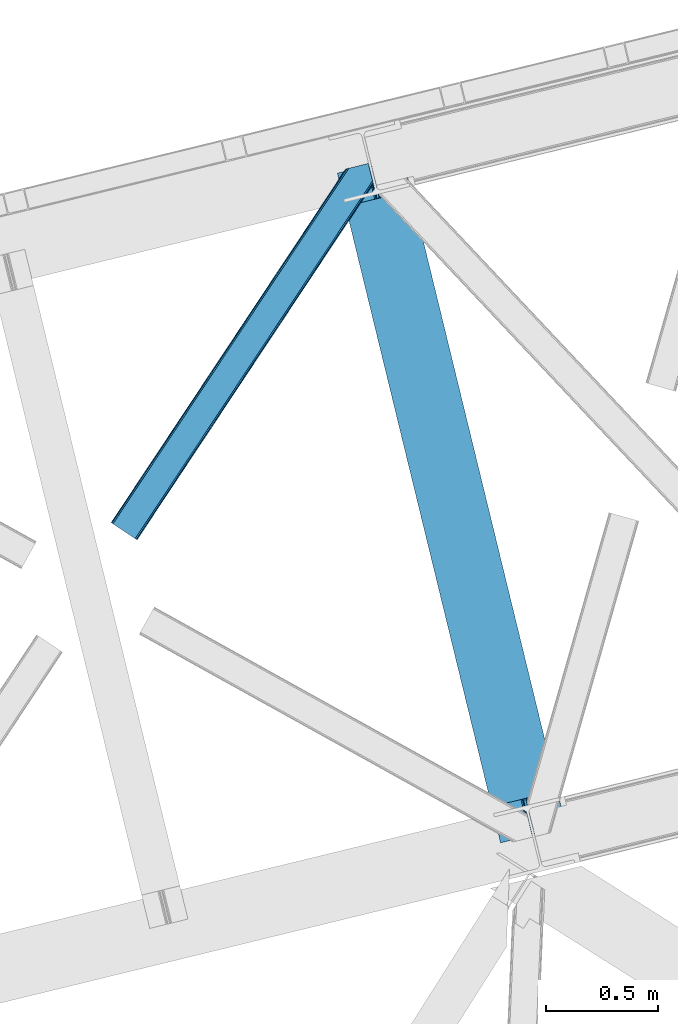
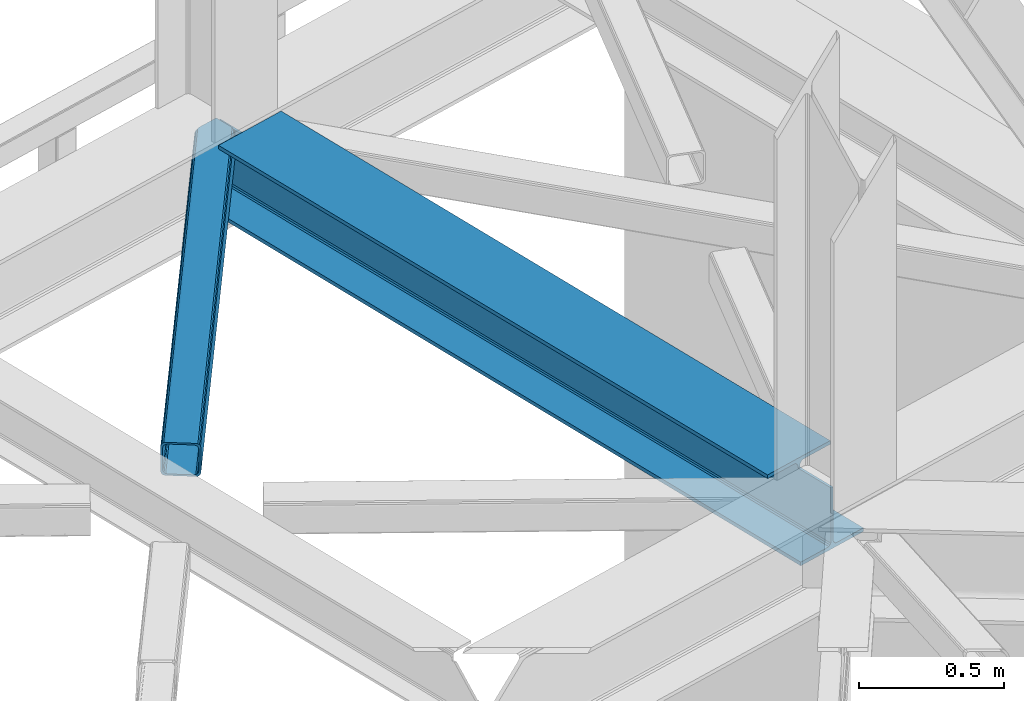
# One storey, part 83 of 93: 1 beam, 1 member.
"""IFC4 building model written with IfcOpenShell, lengths in millimetres."""

from ifc_helpers import new_model, entity, si_unit, converted_unit, derived_unit, direction, frame, origin, place, context, subcontext, project, spatial, triangles, polygons, material, type_object, element, save


model = new_model("IFC4")

# Units and contexts
model_context = context("Model", 3, precision=0.01, world=origin(), true_north=direction((6.12303176911189e-17, 1.0)))
plan_context = context("Plan", 3, precision=0.01, world=origin(), true_north=direction((6.12303176911189e-17, 1.0)))
body_context = subcontext(model_context, "Body", "Model", "MODEL_VIEW")
ifc_project = project(units=[si_unit("LENGTHUNIT", "METRE", prefix="MILLI"), si_unit("AREAUNIT", "SQUARE_METRE"), si_unit("VOLUMEUNIT", "CUBIC_METRE"), converted_unit("PLANEANGLEUNIT", "DEGREE", entity("IfcRatioMeasure", 0.0174532925199433), si_unit("PLANEANGLEUNIT", "RADIAN"), dimensions=[0, 0, 0, 0, 0, 0, 0]), si_unit("MASSUNIT", "GRAM", prefix="KILO"), derived_unit("MASSDENSITYUNIT", [(si_unit("MASSUNIT", "GRAM", prefix="KILO"), 1), (si_unit("LENGTHUNIT", "METRE"), -3)]), derived_unit("MOMENTOFINERTIAUNIT", [(si_unit("LENGTHUNIT", "METRE"), 4)]), si_unit("TIMEUNIT", "SECOND"), si_unit("FREQUENCYUNIT", "HERTZ"), si_unit("THERMODYNAMICTEMPERATUREUNIT", "DEGREE_CELSIUS"), derived_unit("THERMALTRANSMITTANCEUNIT", [(si_unit("MASSUNIT", "GRAM", prefix="KILO"), 1), (si_unit("THERMODYNAMICTEMPERATUREUNIT", "KELVIN"), -1), (si_unit("TIMEUNIT", "SECOND"), -3)]), derived_unit("VOLUMETRICFLOWRATEUNIT", [(si_unit("LENGTHUNIT", "METRE"), 3), (si_unit("TIMEUNIT", "SECOND"), -1)]), derived_unit("MASSFLOWRATEUNIT", [(si_unit("MASSUNIT", "GRAM", prefix="KILO"), 1), (si_unit("TIMEUNIT", "SECOND"), -1)]), derived_unit("ROTATIONALFREQUENCYUNIT", [(si_unit("TIMEUNIT", "SECOND"), -1)]), si_unit("ELECTRICCURRENTUNIT", "AMPERE"), si_unit("ELECTRICVOLTAGEUNIT", "VOLT"), si_unit("POWERUNIT", "WATT"), si_unit("FORCEUNIT", "NEWTON", prefix="KILO"), si_unit("ILLUMINANCEUNIT", "LUX"), si_unit("LUMINOUSFLUXUNIT", "LUMEN"), si_unit("LUMINOUSINTENSITYUNIT", "CANDELA"), derived_unit("USERDEFINED", [(si_unit("MASSUNIT", "GRAM", prefix="KILO"), -1), (si_unit("LENGTHUNIT", "METRE"), -2), (si_unit("TIMEUNIT", "SECOND"), 3), (si_unit("LUMINOUSFLUXUNIT", "LUMEN"), 1)]), derived_unit("LINEARVELOCITYUNIT", [(si_unit("LENGTHUNIT", "METRE"), 1), (si_unit("TIMEUNIT", "SECOND"), -1)]), si_unit("PRESSUREUNIT", "PASCAL"), derived_unit("USERDEFINED", [(si_unit("LENGTHUNIT", "METRE"), -2), (si_unit("MASSUNIT", "GRAM", prefix="KILO"), 1), (si_unit("TIMEUNIT", "SECOND"), -2)]), derived_unit("LINEARFORCEUNIT", [(si_unit("MASSUNIT", "GRAM", prefix="KILO"), 1), (si_unit("LENGTHUNIT", "METRE"), 1), (si_unit("TIMEUNIT", "SECOND"), -2), (si_unit("LENGTHUNIT", "METRE"), -1)]), derived_unit("PLANARFORCEUNIT", [(si_unit("MASSUNIT", "GRAM", prefix="KILO"), 1), (si_unit("LENGTHUNIT", "METRE"), 1), (si_unit("TIMEUNIT", "SECOND"), -2), (si_unit("LENGTHUNIT", "METRE"), -2)])], contexts=[model_context, plan_context])

# Site, building, storey
site_placement = place(None, origin())
site = spatial("IfcSite", under=ifc_project, at=site_placement, CompositionType="ELEMENT")
building_placement = place(site_placement, origin())
building = spatial("IfcBuilding", under=site, at=building_placement, CompositionType="ELEMENT")
storey_placement = place(building_placement, frame((0.0, 0.0, 15900.0)))
storey = spatial("IfcBuildingStorey", under=building, at=storey_placement, CompositionType="ELEMENT", Elevation=15900.0)

# Beam
ifc_material = material(Name="Metal painted (White)")
beam_type = type_object("IfcBeamType", PredefinedType="BEAM")
beam_placement = place(storey_placement, frame((-3043.27889836329, 17053.0977839193, 3385.0)))
element("IfcBeam", 1, at=beam_placement, inside=storey, type_object=beam_type, material=ifc_material, ObjectType="Steel Beam", PredefinedType="BEAM", context=body_context, shape_type="Tessellation", body=[
    polygons([(1018.16648378329, 71.0478278971, 15.4999999999986), (1018.16648378329, 71.0478278971, 0.0), (291.465617442441, 3052.25531830421, 0.0), (291.46561744244, 3052.25531830421, 15.4999999999986), (894.779372399327, 40.970914087327, 15.4999999999986), (168.078506058477, 3022.17840449444, 15.4999999999986), (888.087028625373, 39.3395844888221, 16.8701684147941), (161.386162284522, 3020.54707489593, 16.8701684147941), (882.413533524753, 37.9566100336519, 20.7720779386369), (155.712667183903, 3019.16410044076, 20.7720779386369), (878.622625296174, 37.032536045914, 26.6116982174294), (151.921758955324, 3018.24002645303, 26.6116982174294), (877.29143535278, 36.7080444135029, 33.500000000001), (150.59056901193, 3017.91553482061, 33.500000000001), (140.875048430515, 3015.54727389071, 33.500000000001), (140.875048430516, 3015.54727389071, 259.000000000002), (150.590569011928, 3017.91553482061, 259.000000000002), (5.41433564649196e-13, 2981.20749040711, 0.0), (1.08286712929839e-12, 2981.20749040711, 15.4999999999986), (123.387111383957, 3011.28440421688, 15.4999999999986), (130.079455157929, 3012.91573381539, 16.8701684147963), (135.752950258545, 3014.29870827056, 20.7720779386369), (139.543858487118, 3015.22278225829, 26.6116982174294), (877.291435352778, 36.7080444135029, 259.000000000002), (867.575914771367, 34.3397834835992, 259.000000000002), (867.575914771365, 34.3397834835992, 33.500000000001), (866.244724827968, 34.0152918511816, 26.6116982174294), (862.453816599395, 33.0912178634502, 20.7720779386369), (856.78032149878, 31.70824340828, 16.8701684147963), (850.087977724808, 30.0769138097708, 15.4999999999986), (726.700866340852, -2.16573425859679e-12, 15.4999999999986), (726.700866340851, -2.16573425859679e-12, 0.0), (838.124523615906, 197.385937999179, 259.069791973884), (186.469722099963, 2870.72539801218, 259.000000000002), (186.693115201815, 2869.8089536072, 259.61730333112), (186.705504045442, 2869.75812937344, 266.500003008253), (837.97934480814, 197.9814160017, 266.500002998871), (837.979694928892, 197.979979696968, 260.000004007589), (828.499586345875, 194.645865944432, 259.006343171919), (828.276216326112, 195.562317481909, 259.61730333112), (828.263827482483, 195.613141715683, 266.500003008253), (176.989986719785, 2867.38985508742, 266.500002998871), (176.989636599033, 2867.39129139215, 260.000004007589), (176.844830940693, 2867.98534020594, 259.07612046749), (176.754201518551, 2868.35713708228, 259.000000000002), (839.310832678069, 198.30468544639, 273.388305639783), (843.101109266761, 199.231350618303, 279.227924098781), (848.7741802143, 200.616065081979, 283.129832400619), (855.466371895431, 202.248018612794, 284.500000377228), (978.853400583269, 232.325271667903, 284.500000138971), (978.851730776618, 232.332121736637, 299.999995328161), (687.386308679348, 161.283492472594, 299.999995890962), (687.387978485999, 161.276642403861, 284.500000701776), (810.775007173834, 191.35389545897, 284.500000463519), (817.467494069994, 192.984637925553, 283.129832461069), (823.141405718745, 194.365903570076, 279.227924137322), (826.932940505739, 195.28740721937, 273.388305663684), (175.658498849857, 2867.06658564273, 273.388305639783), (171.868222261161, 2866.13992047082, 279.227924098781), (166.195151313635, 2864.75520600714, 283.129832400619), (159.502959632485, 2863.12325247633, 284.500000377228), (36.115930944656, 2833.04599942122, 284.500000138971), (36.117600751305, 2833.03914935249, 299.999995328161), (327.583022848576, 2904.08777861653, 299.999995890962), (327.581353041926, 2904.09462868526, 284.500000701776), (204.194324354083, 2874.01737563015, 284.500000463519), (197.501837457941, 2872.38663316357, 283.129832461069), (191.827925809177, 2871.00536751904, 279.227924137322), (188.036391022187, 2870.08386386975, 273.388305663684)], [[[1, 2, 3, 4]], [[5, 1, 4, 6]], [[7, 5, 6, 8]], [[9, 7, 8, 10]], [[11, 9, 10, 12]], [[13, 11, 12, 14]], [[15, 16, 17, 14, 12, 10, 8, 6, 4, 3, 18, 19, 20, 21, 22, 23]], [[13, 24, 25, 26, 27, 28, 29, 30, 31, 32, 2, 1, 5, 7, 9, 11]], [[2, 32, 18, 3]], [[32, 31, 19, 18]], [[31, 30, 20, 19]], [[27, 26, 15, 23]], [[28, 27, 23, 22]], [[29, 28, 22, 21]], [[30, 29, 21, 20]], [[33, 24, 13, 14, 17, 34, 35, 36, 37, 38]], [[25, 39, 40, 41, 42, 43, 44, 16, 15, 26]], [[39, 25, 24, 33]], [[45, 34, 17, 16]], [[41, 40, 38, 37, 46, 47, 48, 49, 50, 51, 52, 53, 54, 55, 56, 57]], [[42, 58, 59, 60, 61, 62, 63, 64, 65, 66, 67, 68, 69, 36, 35, 43]], [[46, 37, 36, 69]], [[47, 46, 69, 68]], [[48, 47, 68, 67]], [[49, 48, 67, 66]], [[50, 49, 66, 65]], [[51, 50, 65, 64]], [[52, 51, 64, 63]], [[53, 52, 63, 62]], [[54, 53, 62, 61]], [[55, 54, 61, 60]], [[56, 55, 60, 59]], [[57, 56, 59, 58]], [[41, 57, 58, 42]]], closed=False),
])

# Member
member_type = type_object("IfcMemberType", PredefinedType="BRACE")
member_placement = place(storey_placement, frame((-4050.77483825684, 18401.5802764893, 3510.01988525391)))
element("IfcMember", 2, at=member_placement, inside=storey, type_object=member_type, ObjectType="Steel Horizontal Brace", PredefinedType="BRACE", context=body_context, shape_type="Tessellation", body=[
    triangles([(1012.13822021484, 1571.4587310791, 0.0), (1045.99690933228, 1432.55790710449, 0.0), (14.5796333312987, 67.7191223144546, 0.0), (102.080397033692, 9.67499084472729, 0.0), (1.10807189941397, 76.6569488525383, 10.8039916992202), (0.0, 77.3929504394546, 17.5000946044929), (1043.79529953003, 1650.83760681152, 17.5000946044929), (1007.73296585083, 1592.73185119629, 9.25873718261573), (4.27125091552716, 74.5605651855476, 5.12643127441333), (1007.87191085815, 1593.1829864502, 9.50058288574292), (1007.5829750061, 1592.24815979004, 9.00061340332104), (1007.43734436035, 1591.76446838379, 8.74248962402271), (1007.29839935303, 1591.31333312989, 8.50064392089917), (1008.14776611328, 1587.8298248291, 5.12643127441333), (1046.0907989502, 1651.39571228027, 10.8702667236321), (1046.56518859863, 1651.51198425293, 9.50058288574292), (1009.97875900269, 1580.31865539551, 1.33247680664135), (9.00003204345694, 71.4212219238289, 1.33247680664135), (1043.79529953003, 1650.83760681152, 122.499499511719), (0.0, 77.3929504394546, 122.499499511719), (1045.70215988159, 1651.30269470215, 129.196765136719), (1.10807189941397, 76.6569488525383, 129.196765136719), (1051.1335144043, 1652.62586975098, 134.87548828125), (4.27125091552716, 74.5605651855476, 134.87548828125), (1059.25772781372, 1654.60481872559, 138.668280029298), (9.00003204345694, 71.4212219238289, 138.668280029298), (1068.84609603882, 1656.94421081543, 140.000756835936), (14.5796333312987, 67.7191223144546, 140.000756835936), (1012.24141159058, 1575.25849914551, 9.50058288574292), (1011.99578704834, 1574.65621032715, 9.42384338378906), (1012.03008728027, 1573.63069152832, 9.11688537597729), (1012.0707824707, 1572.60052185059, 8.80760192871094), (1012.10973358154, 1571.57732849121, 8.50064392089917), (1065.96342315674, 1656.23960266114, 9.50058288574292), (14.8357223510743, 67.5516906738303, 8.3320495605476), (20.4150329589843, 63.8495910644524, 7.00073547363354), (1014.39534988403, 1562.19883117676, 7.00073547363354), (10.1022903442381, 70.6898712158218, 12.1260040283196), (1061.15121688843, 1655.06758117676, 12.1260040283196), (1012.24228363037, 1571.03317565918, 8.41343994140698), (1055.7242225647, 1653.74440612793, 17.8035644531265), (1053.81300201416, 1653.27931823731, 24.5008300781265), (6.94376220703134, 72.7874176025398, 17.8035644531265), (5.83074874877912, 73.5234191894524, 24.5008300781265), (1043.73948898315, 1441.81780700684, 7.00073547363354), (96.244997406006, 13.5445220947258, 7.00073547363354), (1045.89284591675, 1432.98578796387, 8.41343994140698), (1046.02539596558, 1432.44163513184, 8.50064392089917), (1050.83643951416, 1412.70330505371, 8.50064392089917), (1049.98707275391, 1416.18913879395, 5.12643127441333), (1048.15637054443, 1423.69798278809, 1.33247680664135), (1053.81300201416, 1653.27931823731, 115.499926757813), (5.83074874877912, 73.5234191894524, 115.499926757813), (1069.28008117676, 1657.04885559082, 131.668707275392), (1078.86844940186, 1659.38592224121, 133.00118408203), (20.4150329589843, 63.8495910644524, 133.00118408203), (14.8357223510743, 67.5516906738303, 131.668707275392), (1061.15121688843, 1655.06758117676, 127.875915527344), (10.1022903442381, 70.6898712158218, 127.875915527344), (1055.7242225647, 1653.74440612793, 122.197192382813), (6.94376220703134, 72.7874176025398, 122.197192382813), (1145.26875686646, 1675.57098083496, 140.000756835936), (1145.26875686646, 1675.57098083496, 133.00118408203), (1161.91250839233, 1607.29375305176, 140.000756835936), (102.080397033692, 9.67499084472729, 140.000756835936), (1159.65537872314, 1616.5536529541, 133.00118408203), (96.244997406006, 13.5445220947258, 133.00118408203), (1164.07226028442, 1598.43382873535, 138.668280029298), (107.659998321533, 5.97289123535302, 138.668280029298), (1165.9029624939, 1590.92265930176, 134.87548828125), (112.388779449463, 2.83354797363427, 134.87548828125), (1167.12614364624, 1585.90436096191, 129.196765136719), (115.551958465576, 0.737164306639897, 129.196765136719), (1167.55576858521, 1584.14167785645, 122.499499511719), (116.660321044922, 0.0, 122.499499511719), (1167.55576858521, 1584.14167785645, 17.5000946044929), (116.660321044922, 0.0, 17.5000946044929), (106.557740020752, 6.7042419433601, 127.875915527344), (109.716268157959, 4.60553283691479, 122.197192382813), (110.829281616211, 3.87069396972583, 115.499926757813), (101.824308013916, 9.84125976562427, 131.668707275392), (115.551958465576, 0.737164306639897, 10.8039916992202), (106.557740020752, 6.7042419433601, 12.1260040283196), (112.388779449463, 2.83354797363427, 5.12643127441333), (110.829281616211, 3.87069396972583, 24.5008300781265), (109.716268157959, 4.60553283691479, 17.8035644531265), (107.659998321533, 5.97289123535302, 1.33247680664135), (101.824308013916, 9.84125976562427, 8.3320495605476), (1165.29834823608, 1593.40157775879, 115.499926757813), (1165.29834823608, 1593.40157775879, 24.5008300781265), (1164.86901397705, 1595.16426086426, 122.197192382813), (1163.64554214478, 1600.1825592041, 127.875915527344), (1161.8148399353, 1607.6937286377, 131.668707275392), (1164.7812286377, 1595.52470397949, 17.8698394775383), (1167.54646682739, 1584.18121032715, 16.5001556396492), (1164.67425842285, 1595.96188659668, 16.5001556396492), (1050.96404800415, 1412.49401550293, 8.8831787109375), (1051.5055847168, 1412.90561828614, 9.29943237304542), (1051.768359375, 1413.10328063965, 9.50058288574292), (1162.81652297974, 1579.82333679199, 10.8714294433594), (1161.66310501099, 1578.76061096192, 9.50058288574292), (1160.35097579956, 1595.22007141114, 12.1260040283196), (1046.70355224609, 1430.89521789551, 9.20757751464771), (1046.36229400635, 1431.66726379394, 8.85411071777344), (1047.39885864258, 1431.02776794434, 9.50058288574292), (1157.29360427856, 1596.68742370605, 9.50058288574292)], [[1, 2, 3], [4, 3, 2], [5, 6, 7], [8, 9, 10], [9, 8, 11], [12, 9, 11], [9, 12, 13], [13, 14, 9], [5, 15, 10], [10, 9, 5], [15, 16, 10], [17, 1, 18], [3, 18, 1], [14, 17, 9], [18, 9, 17], [7, 15, 5], [19, 7, 6], [6, 20, 19], [21, 19, 22], [20, 22, 19], [23, 21, 24], [22, 24, 21], [25, 23, 26], [24, 26, 23], [27, 25, 28], [26, 28, 25], [8, 10, 29], [11, 8, 30], [12, 11, 31], [13, 12, 32], [32, 33, 13], [31, 32, 12], [30, 31, 11], [29, 30, 8], [16, 34, 29], [29, 10, 16], [35, 36, 37], [38, 30, 29], [29, 39, 38], [29, 34, 39], [38, 35, 40], [40, 33, 38], [31, 38, 32], [31, 30, 38], [38, 33, 32], [37, 40, 35], [41, 42, 43], [44, 43, 42], [39, 41, 38], [43, 38, 41], [45, 37, 36], [36, 46, 45], [1, 37, 45], [13, 33, 14], [33, 40, 1], [37, 1, 40], [33, 17, 14], [33, 1, 17], [2, 1, 45], [2, 45, 47], [48, 2, 47], [49, 50, 48], [48, 51, 2], [48, 50, 51], [42, 52, 53], [53, 44, 42], [54, 55, 56], [56, 57, 54], [58, 54, 57], [57, 59, 58], [60, 58, 59], [59, 61, 60], [52, 60, 61], [61, 53, 52], [60, 19, 21], [54, 25, 27], [62, 55, 27], [55, 62, 63], [55, 54, 27], [58, 25, 54], [58, 60, 23], [23, 25, 58], [21, 23, 60], [42, 7, 19], [39, 16, 41], [60, 52, 19], [39, 34, 16], [42, 41, 7], [52, 42, 19], [15, 7, 41], [41, 16, 15], [64, 27, 65], [27, 64, 62], [28, 65, 27], [55, 66, 67], [55, 63, 66], [67, 56, 55], [68, 64, 65], [65, 69, 68], [70, 68, 69], [69, 71, 70], [72, 70, 71], [71, 73, 72], [74, 72, 73], [73, 75, 74], [76, 74, 75], [75, 77, 76], [73, 78, 79], [80, 77, 75], [73, 79, 75], [73, 71, 78], [79, 80, 75], [78, 71, 69], [67, 65, 28], [65, 81, 69], [81, 65, 67], [81, 78, 69], [82, 83, 84], [85, 77, 80], [77, 86, 82], [86, 77, 85], [82, 86, 83], [4, 46, 3], [87, 84, 83], [83, 88, 87], [88, 46, 4], [4, 87, 88], [59, 26, 24], [28, 56, 67], [28, 57, 56], [57, 28, 26], [59, 57, 26], [53, 20, 6], [22, 61, 59], [24, 22, 59], [61, 22, 20], [53, 61, 20], [18, 38, 9], [3, 46, 36], [36, 35, 3], [35, 38, 18], [18, 3, 35], [5, 9, 38], [6, 44, 53], [43, 6, 5], [6, 43, 44], [43, 5, 38], [89, 90, 80], [85, 80, 90], [91, 89, 79], [80, 79, 89], [92, 91, 78], [79, 78, 91], [93, 92, 81], [78, 81, 92], [66, 93, 67], [81, 67, 93], [94, 95, 96], [74, 76, 90], [76, 94, 90], [90, 89, 74], [76, 95, 94], [91, 74, 89], [72, 74, 91], [70, 91, 92], [91, 70, 72], [92, 68, 70], [93, 68, 92], [93, 66, 64], [93, 64, 68], [66, 62, 64], [66, 63, 62], [82, 97, 98], [99, 100, 82], [99, 101, 100], [84, 50, 97], [97, 82, 84], [77, 82, 100], [100, 76, 77], [100, 95, 76], [51, 50, 87], [84, 87, 50], [2, 51, 4], [87, 4, 51], [86, 85, 90], [86, 96, 102], [86, 94, 96], [103, 104, 88], [48, 88, 104], [83, 102, 105], [105, 88, 83], [102, 106, 105], [46, 88, 48], [48, 45, 46], [102, 83, 86], [90, 94, 86], [97, 48, 104], [97, 104, 105], [106, 101, 105], [99, 105, 101], [102, 95, 100], [102, 96, 95], [102, 101, 106], [100, 101, 102]]),
])

save(model, "model.ifc")
